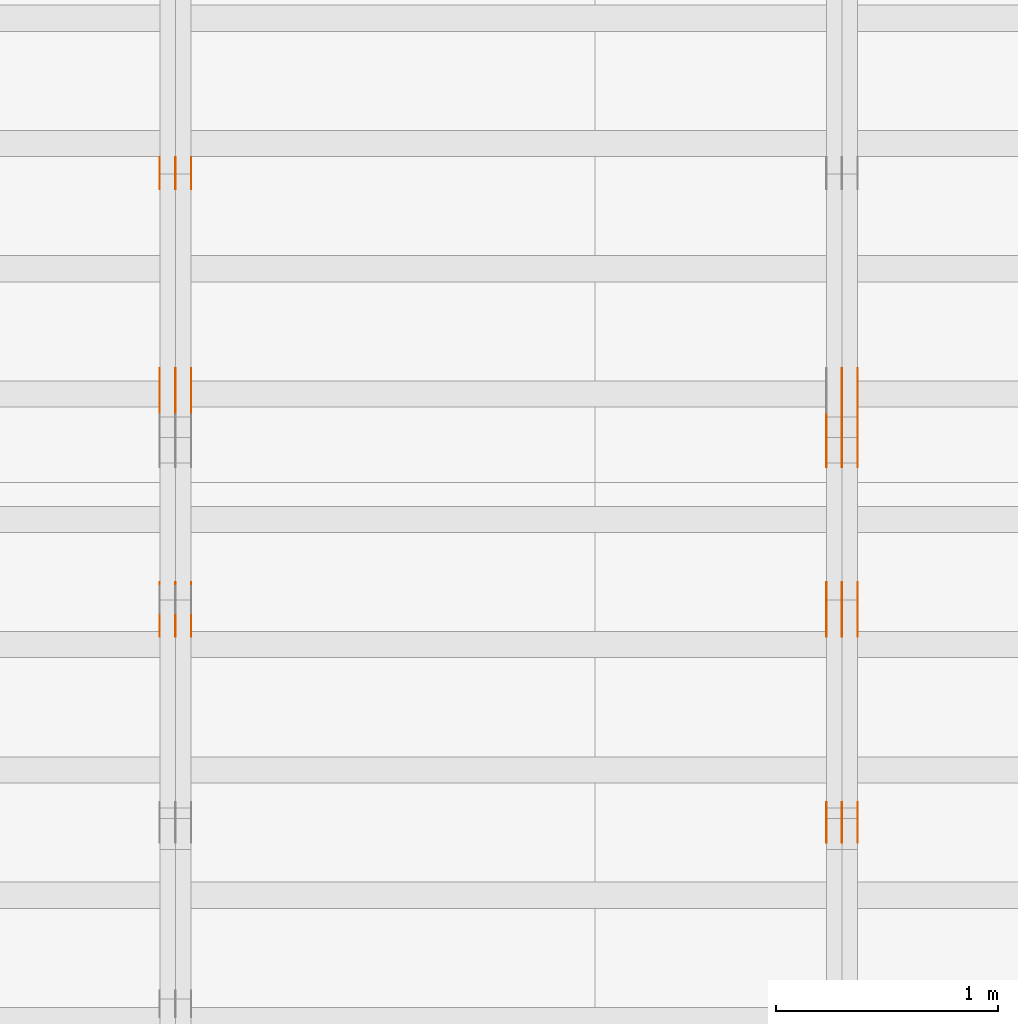
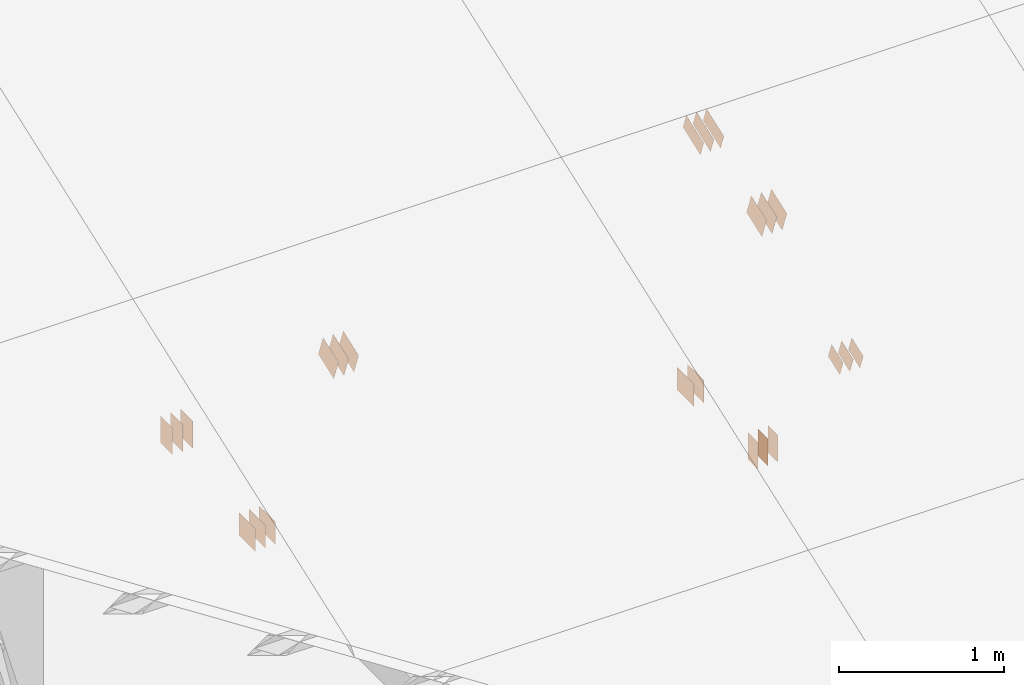
# One storey, part 71 of 189: 31 proxies.
"""IFC2X3 building model written with IfcOpenShell, lengths in millimetres."""

from ifc_helpers import new_model, entity, si_unit, converted_unit, derived_unit, direction, frame, frame_2d, origin, origin_2d_with_axis, place, context, subcontext, project, spatial, polyline, rectangle, outline, extrude, source, transform, mapped, material, type_object, type_shapes, element, save


model = new_model("IFC2X3")

# Units and contexts
model_context = context("Model", 3, precision=0.01, world=origin(), true_north=direction((6.12303176911189e-17, 1.0)))
body_context = subcontext(model_context, "Body", "Model", "MODEL_VIEW")
ifc_project = project(units=[si_unit("LENGTHUNIT", "METRE", prefix="MILLI"), si_unit("AREAUNIT", "SQUARE_METRE"), si_unit("VOLUMEUNIT", "CUBIC_METRE"), converted_unit("PLANEANGLEUNIT", "DEGREE", entity("IfcRatioMeasure", 0.0174532925199433), si_unit("PLANEANGLEUNIT", "RADIAN"), dimensions=[0, 0, 0, 0, 0, 0, 0]), si_unit("MASSUNIT", "GRAM", prefix="KILO"), derived_unit("MASSDENSITYUNIT", [(si_unit("MASSUNIT", "GRAM", prefix="KILO"), 1), (si_unit("LENGTHUNIT", "METRE"), -3)]), si_unit("TIMEUNIT", "SECOND"), si_unit("FREQUENCYUNIT", "HERTZ"), si_unit("THERMODYNAMICTEMPERATUREUNIT", "DEGREE_CELSIUS"), derived_unit("THERMALTRANSMITTANCEUNIT", [(si_unit("MASSUNIT", "GRAM", prefix="KILO"), 1), (si_unit("THERMODYNAMICTEMPERATUREUNIT", "KELVIN"), -1), (si_unit("TIMEUNIT", "SECOND"), -3)]), derived_unit("VOLUMETRICFLOWRATEUNIT", [(si_unit("LENGTHUNIT", "METRE"), 3), (si_unit("TIMEUNIT", "SECOND"), -1)]), si_unit("ELECTRICCURRENTUNIT", "AMPERE"), si_unit("ELECTRICVOLTAGEUNIT", "VOLT"), si_unit("POWERUNIT", "WATT"), si_unit("FORCEUNIT", "NEWTON"), si_unit("ILLUMINANCEUNIT", "LUX"), si_unit("LUMINOUSFLUXUNIT", "LUMEN"), si_unit("LUMINOUSINTENSITYUNIT", "CANDELA"), derived_unit("USERDEFINED", [(si_unit("MASSUNIT", "GRAM", prefix="KILO"), -1), (si_unit("LENGTHUNIT", "METRE"), -2), (si_unit("TIMEUNIT", "SECOND"), 3), (si_unit("LUMINOUSFLUXUNIT", "LUMEN"), 1)]), derived_unit("LINEARVELOCITYUNIT", [(si_unit("LENGTHUNIT", "METRE"), 1), (si_unit("TIMEUNIT", "SECOND"), -1)]), si_unit("PRESSUREUNIT", "PASCAL"), derived_unit("USERDEFINED", [(si_unit("LENGTHUNIT", "METRE"), -2), (si_unit("MASSUNIT", "GRAM", prefix="KILO"), 1), (si_unit("TIMEUNIT", "SECOND"), -2)])], contexts=[model_context])

# Site, building, storey
site_placement = place(None, origin())
site = spatial("IfcSite", under=ifc_project, at=site_placement, CompositionType="ELEMENT")
building_placement = place(site_placement, origin())
building = spatial("IfcBuilding", under=site, at=building_placement, CompositionType="ELEMENT")
storey_placement = place(building_placement, origin())
storey = spatial("IfcBuildingStorey", under=building, at=storey_placement, Name="Default", CompositionType="ELEMENT", Elevation=0.0)

# Proxies
ifc_material_1 = material(Name="IfcSurfaceStyle #47194")
building_element_proxy_type_1 = type_object("IfcBuildingElementProxyType", PredefinedType="NOTDEFINED", material=ifc_material_1)
shared_shape_1 = source(origin(), body_context, "Body", "SweptSolid", [
    extrude(rectangle(XDim=200.0, YDim=168.0, at=origin_2d_with_axis()), frame((100.0, 84.0, 0.0), z_axis=(0.0, 0.0, 1.0), x_axis=(-1.0, 0.0, 0.0)), (0.0, 0.0, 1.0), 1.3),
])
type_shapes(building_element_proxy_type_1, [shared_shape_1])
proxy_1_placement = place(building_placement, frame((6336.3, 5662.466796875, 206.5), z_axis=(-1.0, 0.0, 0.0), x_axis=(0.0, 1.0, 0.0)))
element("IfcBuildingElementProxy", 1, at=proxy_1_placement, inside=storey, type_object=building_element_proxy_type_1, material=ifc_material_1, context=body_context, shape_type="MappedRepresentation", body=[
    mapped(shared_shape_1, transform((0.0, 0.0, 0.0), scale=1.0)),
])
ifc_material_2 = material(Name="IfcSurfaceStyle #47137")
building_element_proxy_type_2 = type_object("IfcBuildingElementProxyType", PredefinedType="NOTDEFINED", material=ifc_material_2)
shared_shape_2 = source(origin(), body_context, "Body", "SweptSolid", [
    extrude(rectangle(XDim=200.0, YDim=168.0, at=origin_2d_with_axis()), frame((100.0, 84.0, 0.0), z_axis=(0.0, 0.0, 1.0), x_axis=(-1.0, 0.0, 0.0)), (0.0, 0.0, 1.0), 1.29999999999998),
])
type_shapes(building_element_proxy_type_2, [shared_shape_2])
proxy_2_placement = place(building_placement, frame((6265.0, 5662.466796875, 206.5), z_axis=(-1.0, 0.0, 0.0), x_axis=(0.0, 1.0, 0.0)))
element("IfcBuildingElementProxy", 2, at=proxy_2_placement, inside=storey, type_object=building_element_proxy_type_2, material=ifc_material_2, context=body_context, shape_type="MappedRepresentation", body=[
    mapped(shared_shape_2, transform((0.0, 0.0, 0.0), scale=1.0)),
])
ifc_material_3 = material(Name="IfcSurfaceStyle #47080")
building_element_proxy_type_3 = type_object("IfcBuildingElementProxyType", PredefinedType="NOTDEFINED", material=ifc_material_3)
shared_shape_3 = source(origin(), body_context, "Body", "SweptSolid", [
    extrude(rectangle(XDim=200.0, YDim=168.0, at=origin_2d_with_axis()), frame((100.0, 84.0, 0.0), z_axis=(0.0, 0.0, 1.0), x_axis=(-1.0, 0.0, 0.0)), (0.0, 0.0, 1.0), 1.29999999999998),
])
type_shapes(building_element_proxy_type_3, [shared_shape_3])
proxy_3_placement = place(building_placement, frame((6266.3, 5662.466796875, 206.5), z_axis=(-1.0, 0.0, 0.0), x_axis=(0.0, 1.0, 0.0)))
element("IfcBuildingElementProxy", 3, at=proxy_3_placement, inside=storey, type_object=building_element_proxy_type_3, material=ifc_material_3, context=body_context, shape_type="MappedRepresentation", body=[
    mapped(shared_shape_3, transform((0.0, 0.0, 0.0), scale=1.0)),
])
ifc_material_4 = material(Name="IfcSurfaceStyle #43546")
building_element_proxy_type_4 = type_object("IfcBuildingElementProxyType", PredefinedType="NOTDEFINED", material=ifc_material_4)
shared_shape_4 = source(origin(), body_context, "Body", "SweptSolid", [
    extrude(outline(polyline([(-112.500654374667, -59.9999021691247), (112.500117969231, -59.9999021691247), (112.500612624162, 59.9999021691247), (-112.500076218726, 59.9999021691247), (-112.500654374667, -59.9999021691247)])), frame((112.500612624162, 60.0003514046321, 0.0), z_axis=(0.0, 0.0, 1.0), x_axis=(-1.0, 0.0, 0.0)), (0.0, 0.0, 1.0), 1.3),
])
type_shapes(building_element_proxy_type_4, [shared_shape_4])
proxy_4_placement = place(building_placement, frame((6336.3, 5418.0703125, 2162.37353515625), z_axis=(-1.0, 0.0, 0.0), x_axis=(0.0, 0.939692620785908, 0.342020143325669)))
element("IfcBuildingElementProxy", 4, at=proxy_4_placement, inside=storey, type_object=building_element_proxy_type_4, material=ifc_material_4, context=body_context, shape_type="MappedRepresentation", body=[
    mapped(shared_shape_4, transform((0.0, 0.0, 0.0), scale=1.0)),
])
ifc_material_5 = material(Name="IfcSurfaceStyle #43489")
building_element_proxy_type_5 = type_object("IfcBuildingElementProxyType", PredefinedType="NOTDEFINED", material=ifc_material_5)
shared_shape_5 = source(origin(), body_context, "Body", "SweptSolid", [
    extrude(outline(polyline([(-112.500654374667, -59.9999021691247), (112.500117969231, -59.9999021691247), (112.500612624162, 59.9999021691247), (-112.500076218726, 59.9999021691247), (-112.500654374667, -59.9999021691247)])), frame((112.500612624162, 60.0003514046321, 0.0), z_axis=(0.0, 0.0, 1.0), x_axis=(-1.0, 0.0, 0.0)), (0.0, 0.0, 1.0), 1.29999999999998),
])
type_shapes(building_element_proxy_type_5, [shared_shape_5])
proxy_5_placement = place(building_placement, frame((6265.0, 5418.0703125, 2162.37353515625), z_axis=(-1.0, 0.0, 0.0), x_axis=(0.0, 0.939692620785908, 0.342020143325669)))
element("IfcBuildingElementProxy", 5, at=proxy_5_placement, inside=storey, type_object=building_element_proxy_type_5, material=ifc_material_5, context=body_context, shape_type="MappedRepresentation", body=[
    mapped(shared_shape_5, transform((0.0, 0.0, 0.0), scale=1.0)),
])
ifc_material_6 = material(Name="IfcSurfaceStyle #43432")
building_element_proxy_type_6 = type_object("IfcBuildingElementProxyType", PredefinedType="NOTDEFINED", material=ifc_material_6)
shared_shape_6 = source(origin(), body_context, "Body", "SweptSolid", [
    extrude(outline(polyline([(-112.500654374667, -59.9999021691247), (112.500117969231, -59.9999021691247), (112.500612624162, 59.9999021691247), (-112.500076218726, 59.9999021691247), (-112.500654374667, -59.9999021691247)])), frame((112.500612624162, 60.0003514046321, 0.0), z_axis=(0.0, 0.0, 1.0), x_axis=(-1.0, 0.0, 0.0)), (0.0, 0.0, 1.0), 1.29999999999998),
])
type_shapes(building_element_proxy_type_6, [shared_shape_6])
proxy_6_placement = place(building_placement, frame((6266.3, 5418.0703125, 2162.37353515625), z_axis=(-1.0, 0.0, 0.0), x_axis=(0.0, 0.939692620785908, 0.342020143325669)))
element("IfcBuildingElementProxy", 6, at=proxy_6_placement, inside=storey, type_object=building_element_proxy_type_6, material=ifc_material_6, context=body_context, shape_type="MappedRepresentation", body=[
    mapped(shared_shape_6, transform((0.0, 0.0, 0.0), scale=1.0)),
])
ifc_material_7 = material(Name="IfcSurfaceStyle #43375")
building_element_proxy_type_7 = type_object("IfcBuildingElementProxyType", PredefinedType="NOTDEFINED", material=ifc_material_7)
shared_shape_7 = source(origin(), body_context, "Body", "SweptSolid", [
    extrude(outline(polyline([(-112.500654374667, -59.9999021691247), (112.500117969231, -59.9999021691247), (112.500612624162, 59.9999021691247), (-112.500076218726, 59.9999021691247), (-112.500654374667, -59.9999021691247)])), frame((112.500612624162, 60.0003514046321, 0.0), z_axis=(0.0, 0.0, 1.0), x_axis=(-1.0, 0.0, 0.0)), (0.0, 0.0, 1.0), 1.29999999999999),
])
type_shapes(building_element_proxy_type_7, [shared_shape_7])
proxy_7_placement = place(building_placement, frame((6195.0, 5418.0703125, 2162.37353515625), z_axis=(-1.0, 0.0, 0.0), x_axis=(0.0, 0.939692620785908, 0.342020143325669)))
element("IfcBuildingElementProxy", 7, at=proxy_7_placement, inside=storey, type_object=building_element_proxy_type_7, material=ifc_material_7, context=body_context, shape_type="MappedRepresentation", body=[
    mapped(shared_shape_7, transform((0.0, 0.0, 0.0), scale=1.0)),
])
ifc_material_8 = material(Name="IfcSurfaceStyle #42862")
building_element_proxy_type_8 = type_object("IfcBuildingElementProxyType", PredefinedType="NOTDEFINED", material=ifc_material_8)
shared_shape_8 = source(origin(), body_context, "Body", "SweptSolid", [
    extrude(rectangle(XDim=200.0, YDim=120.0, at=origin_2d_with_axis()), frame((100.0, 60.0, 0.0), z_axis=(0.0, 0.0, 1.0), x_axis=(-1.0, 0.0, 0.0)), (0.0, 0.0, 1.0), 1.3),
])
type_shapes(building_element_proxy_type_8, [shared_shape_8])
proxy_8_placement = place(building_placement, frame((6336.3, 4760.65625, 145.0), z_axis=(-1.0, 0.0, 0.0), x_axis=(0.0, 0.0, 1.0)))
element("IfcBuildingElementProxy", 8, at=proxy_8_placement, inside=storey, type_object=building_element_proxy_type_8, material=ifc_material_8, context=body_context, shape_type="MappedRepresentation", body=[
    mapped(shared_shape_8, transform((0.0, 0.0, 0.0), scale=1.0)),
])
ifc_material_9 = material(Name="IfcSurfaceStyle #42805")
building_element_proxy_type_9 = type_object("IfcBuildingElementProxyType", PredefinedType="NOTDEFINED", material=ifc_material_9)
shared_shape_9 = source(origin(), body_context, "Body", "SweptSolid", [
    extrude(rectangle(XDim=200.0, YDim=120.0, at=origin_2d_with_axis()), frame((100.0, 60.0, 0.0), z_axis=(0.0, 0.0, 1.0), x_axis=(-1.0, 0.0, 0.0)), (0.0, 0.0, 1.0), 1.29999999999998),
])
type_shapes(building_element_proxy_type_9, [shared_shape_9])
proxy_9_placement = place(building_placement, frame((6265.0, 4760.65625, 145.0), z_axis=(-1.0, 0.0, 0.0), x_axis=(0.0, 0.0, 1.0)))
element("IfcBuildingElementProxy", 9, at=proxy_9_placement, inside=storey, type_object=building_element_proxy_type_9, material=ifc_material_9, context=body_context, shape_type="MappedRepresentation", body=[
    mapped(shared_shape_9, transform((0.0, 0.0, 0.0), scale=1.0)),
])
ifc_material_10 = material(Name="IfcSurfaceStyle #42748")
building_element_proxy_type_10 = type_object("IfcBuildingElementProxyType", PredefinedType="NOTDEFINED", material=ifc_material_10)
shared_shape_10 = source(origin(), body_context, "Body", "SweptSolid", [
    extrude(rectangle(XDim=200.0, YDim=120.0, at=origin_2d_with_axis()), frame((100.0, 60.0, 0.0), z_axis=(0.0, 0.0, 1.0), x_axis=(-1.0, 0.0, 0.0)), (0.0, 0.0, 1.0), 1.29999999999998),
])
type_shapes(building_element_proxy_type_10, [shared_shape_10])
proxy_10_placement = place(building_placement, frame((6266.3, 4760.65625, 145.0), z_axis=(-1.0, 0.0, 0.0), x_axis=(0.0, 0.0, 1.0)))
element("IfcBuildingElementProxy", 10, at=proxy_10_placement, inside=storey, type_object=building_element_proxy_type_10, material=ifc_material_10, context=body_context, shape_type="MappedRepresentation", body=[
    mapped(shared_shape_10, transform((0.0, 0.0, 0.0), scale=1.0)),
])
ifc_material_11 = material(Name="IfcSurfaceStyle #42691")
building_element_proxy_type_11 = type_object("IfcBuildingElementProxyType", PredefinedType="NOTDEFINED", material=ifc_material_11)
shared_shape_11 = source(origin(), body_context, "Body", "SweptSolid", [
    extrude(rectangle(XDim=200.0, YDim=120.0, at=origin_2d_with_axis()), frame((100.0, 60.0, 0.0), z_axis=(0.0, 0.0, 1.0), x_axis=(-1.0, 0.0, 0.0)), (0.0, 0.0, 1.0), 1.29999999999999),
])
type_shapes(building_element_proxy_type_11, [shared_shape_11])
proxy_11_placement = place(building_placement, frame((6195.0, 4760.65625, 145.0), z_axis=(-1.0, 0.0, 0.0), x_axis=(0.0, 0.0, 1.0)))
element("IfcBuildingElementProxy", 11, at=proxy_11_placement, inside=storey, type_object=building_element_proxy_type_11, material=ifc_material_11, context=body_context, shape_type="MappedRepresentation", body=[
    mapped(shared_shape_11, transform((0.0, 0.0, 0.0), scale=1.0)),
])
ifc_material_12 = material(Name="IfcSurfaceStyle #42634")
building_element_proxy_type_12 = type_object("IfcBuildingElementProxyType", PredefinedType="NOTDEFINED", material=ifc_material_12)
shared_shape_12 = source(origin(), body_context, "Body", "SweptSolid", [
    extrude(outline(polyline([(-74.9994515581384, -59.9999039432178), (74.9998536965286, -59.9999039432178), (75.0003483514593, 59.9999039432178), (-75.0007504898495, 59.9999039432178), (-74.9994515581384, -59.9999039432178)])), frame((75.0003483514593, 60.0003496305408, 0.0), z_axis=(0.0, 0.0, 1.0), x_axis=(-1.0, 0.0, 0.0)), (0.0, 0.0, 1.0), 1.3),
])
type_shapes(building_element_proxy_type_12, [shared_shape_12])
proxy_12_placement = place(building_placement, frame((6336.3, 3726.8984375, 1559.607421875), z_axis=(-1.0, 0.0, 0.0), x_axis=(0.0, 0.939692620785908, 0.342020143325669)))
element("IfcBuildingElementProxy", 12, at=proxy_12_placement, inside=storey, type_object=building_element_proxy_type_12, material=ifc_material_12, context=body_context, shape_type="MappedRepresentation", body=[
    mapped(shared_shape_12, transform((0.0, 0.0, 0.0), scale=1.0)),
])
ifc_material_13 = material(Name="IfcSurfaceStyle #42577")
building_element_proxy_type_13 = type_object("IfcBuildingElementProxyType", PredefinedType="NOTDEFINED", material=ifc_material_13)
shared_shape_13 = source(origin(), body_context, "Body", "SweptSolid", [
    extrude(outline(polyline([(-74.9994515581384, -59.9999039432178), (74.9998536965286, -59.9999039432178), (75.0003483514593, 59.9999039432178), (-75.0007504898495, 59.9999039432178), (-74.9994515581384, -59.9999039432178)])), frame((75.0003483514593, 60.0003496305408, 0.0), z_axis=(0.0, 0.0, 1.0), x_axis=(-1.0, 0.0, 0.0)), (0.0, 0.0, 1.0), 1.29999999999999),
])
type_shapes(building_element_proxy_type_13, [shared_shape_13])
proxy_13_placement = place(building_placement, frame((6265.0, 3726.8984375, 1559.607421875), z_axis=(-1.0, 0.0, 0.0), x_axis=(0.0, 0.939692620785908, 0.342020143325669)))
element("IfcBuildingElementProxy", 13, at=proxy_13_placement, inside=storey, type_object=building_element_proxy_type_13, material=ifc_material_13, context=body_context, shape_type="MappedRepresentation", body=[
    mapped(shared_shape_13, transform((0.0, 0.0, 0.0), scale=1.0)),
])
ifc_material_14 = material(Name="IfcSurfaceStyle #42520")
building_element_proxy_type_14 = type_object("IfcBuildingElementProxyType", PredefinedType="NOTDEFINED", material=ifc_material_14)
shared_shape_14 = source(origin(), body_context, "Body", "SweptSolid", [
    extrude(outline(polyline([(-74.9994515581384, -59.9999039432178), (74.9998536965286, -59.9999039432178), (75.0003483514593, 59.9999039432178), (-75.0007504898495, 59.9999039432178), (-74.9994515581384, -59.9999039432178)])), frame((75.0003483514593, 60.0003496305408, 0.0), z_axis=(0.0, 0.0, 1.0), x_axis=(-1.0, 0.0, 0.0)), (0.0, 0.0, 1.0), 1.29999999999999),
])
type_shapes(building_element_proxy_type_14, [shared_shape_14])
proxy_14_placement = place(building_placement, frame((6266.3, 3726.8984375, 1559.607421875), z_axis=(-1.0, 0.0, 0.0), x_axis=(0.0, 0.939692620785908, 0.342020143325669)))
element("IfcBuildingElementProxy", 14, at=proxy_14_placement, inside=storey, type_object=building_element_proxy_type_14, material=ifc_material_14, context=body_context, shape_type="MappedRepresentation", body=[
    mapped(shared_shape_14, transform((0.0, 0.0, 0.0), scale=1.0)),
])
ifc_material_15 = material(Name="IfcSurfaceStyle #42463")
building_element_proxy_type_15 = type_object("IfcBuildingElementProxyType", PredefinedType="NOTDEFINED", material=ifc_material_15)
shared_shape_15 = source(origin(), body_context, "Body", "SweptSolid", [
    extrude(outline(polyline([(-74.9994515581384, -59.9999039432178), (74.9998536965286, -59.9999039432178), (75.0003483514593, 59.9999039432178), (-75.0007504898495, 59.9999039432178), (-74.9994515581384, -59.9999039432178)])), frame((75.0003483514593, 60.0003496305408, 0.0), z_axis=(0.0, 0.0, 1.0), x_axis=(-1.0, 0.0, 0.0)), (0.0, 0.0, 1.0), 1.29999999999999),
])
type_shapes(building_element_proxy_type_15, [shared_shape_15])
proxy_15_placement = place(building_placement, frame((6195.0, 3726.8984375, 1559.607421875), z_axis=(-1.0, 0.0, 0.0), x_axis=(0.0, 0.939692620785908, 0.342020143325669)))
element("IfcBuildingElementProxy", 15, at=proxy_15_placement, inside=storey, type_object=building_element_proxy_type_15, material=ifc_material_15, context=body_context, shape_type="MappedRepresentation", body=[
    mapped(shared_shape_15, transform((0.0, 0.0, 0.0), scale=1.0)),
])
ifc_material_16 = material(Name="IfcSurfaceStyle #37966")
building_element_proxy_type_16 = type_object("IfcBuildingElementProxyType", PredefinedType="NOTDEFINED", material=ifc_material_16)
shared_shape_16 = source(origin(), body_context, "Body", "SweptSolid", [
    extrude(outline(polyline([(-99.9993269270171, -84.0000832532405), (99.9997189122032, -84.0000832532405), (99.9992851765118, 84.0000832532405), (-99.999677161698, 84.0000832532405), (-99.9993269270171, -84.0000832532405)])), frame((99.9999283659736, 84.0000832532405, 0.0), z_axis=(0.0, 0.0, 1.0), x_axis=(-1.0, 0.0, 0.0)), (0.0, 0.0, 1.0), 1.3),
])
type_shapes(building_element_proxy_type_16, [shared_shape_16])
proxy_16_placement = place(building_placement, frame((6336.3, 4654.06379965055, 2052.96988554922), z_axis=(-1.0, 0.0, 0.0), x_axis=(0.0, 0.939692620785908, 0.342020143325669)))
element("IfcBuildingElementProxy", 16, at=proxy_16_placement, inside=storey, type_object=building_element_proxy_type_16, material=ifc_material_16, context=body_context, shape_type="MappedRepresentation", body=[
    mapped(shared_shape_16, transform((0.0, 0.0, 0.0), scale=1.0)),
])
ifc_material_17 = material(Name="IfcSurfaceStyle #37909")
building_element_proxy_type_17 = type_object("IfcBuildingElementProxyType", PredefinedType="NOTDEFINED", material=ifc_material_17)
shared_shape_17 = source(origin(), body_context, "Body", "SweptSolid", [
    extrude(outline(polyline([(-99.9993269270171, -84.0000832532405), (99.9997189122032, -84.0000832532405), (99.9992851765118, 84.0000832532405), (-99.999677161698, 84.0000832532405), (-99.9993269270171, -84.0000832532405)])), frame((99.9999283659736, 84.0000832532405, 0.0), z_axis=(0.0, 0.0, 1.0), x_axis=(-1.0, 0.0, 0.0)), (0.0, 0.0, 1.0), 1.29999999999998),
])
type_shapes(building_element_proxy_type_17, [shared_shape_17])
proxy_17_placement = place(building_placement, frame((6265.0, 4654.06379965055, 2052.96988554922), z_axis=(-1.0, 0.0, 0.0), x_axis=(0.0, 0.939692620785908, 0.342020143325669)))
element("IfcBuildingElementProxy", 17, at=proxy_17_placement, inside=storey, type_object=building_element_proxy_type_17, material=ifc_material_17, context=body_context, shape_type="MappedRepresentation", body=[
    mapped(shared_shape_17, transform((0.0, 0.0, 0.0), scale=1.0)),
])
ifc_material_18 = material(Name="IfcSurfaceStyle #37852")
building_element_proxy_type_18 = type_object("IfcBuildingElementProxyType", PredefinedType="NOTDEFINED", material=ifc_material_18)
shared_shape_18 = source(origin(), body_context, "Body", "SweptSolid", [
    extrude(outline(polyline([(-99.9993269270171, -84.0000832532405), (99.9997189122032, -84.0000832532405), (99.9992851765118, 84.0000832532405), (-99.999677161698, 84.0000832532405), (-99.9993269270171, -84.0000832532405)])), frame((99.9999283659736, 84.0000832532405, 0.0), z_axis=(0.0, 0.0, 1.0), x_axis=(-1.0, 0.0, 0.0)), (0.0, 0.0, 1.0), 1.29999999999998),
])
type_shapes(building_element_proxy_type_18, [shared_shape_18])
proxy_18_placement = place(building_placement, frame((6266.3, 4654.06379965055, 2052.96988554922), z_axis=(-1.0, 0.0, 0.0), x_axis=(0.0, 0.939692620785908, 0.342020143325669)))
element("IfcBuildingElementProxy", 18, at=proxy_18_placement, inside=storey, type_object=building_element_proxy_type_18, material=ifc_material_18, context=body_context, shape_type="MappedRepresentation", body=[
    mapped(shared_shape_18, transform((0.0, 0.0, 0.0), scale=1.0)),
])
ifc_material_19 = material(Name="IfcSurfaceStyle #37795")
building_element_proxy_type_19 = type_object("IfcBuildingElementProxyType", PredefinedType="NOTDEFINED", material=ifc_material_19)
shared_shape_19 = source(origin(), body_context, "Body", "SweptSolid", [
    extrude(outline(polyline([(-99.9993269270171, -84.0000832532405), (99.9997189122032, -84.0000832532405), (99.9992851765118, 84.0000832532405), (-99.999677161698, 84.0000832532405), (-99.9993269270171, -84.0000832532405)])), frame((99.9999283659736, 84.0000832532405, 0.0), z_axis=(0.0, 0.0, 1.0), x_axis=(-1.0, 0.0, 0.0)), (0.0, 0.0, 1.0), 1.29999999999999),
])
type_shapes(building_element_proxy_type_19, [shared_shape_19])
proxy_19_placement = place(building_placement, frame((6195.0, 4654.06379965055, 2052.96988554922), z_axis=(-1.0, 0.0, 0.0), x_axis=(0.0, 0.939692620785908, 0.342020143325669)))
element("IfcBuildingElementProxy", 19, at=proxy_19_placement, inside=storey, type_object=building_element_proxy_type_19, material=ifc_material_19, context=body_context, shape_type="MappedRepresentation", body=[
    mapped(shared_shape_19, transform((0.0, 0.0, 0.0), scale=1.0)),
])
ifc_material_20 = material(Name="IfcSurfaceStyle #31632")
building_element_proxy_type_20 = type_object("IfcBuildingElementProxyType", PredefinedType="NOTDEFINED", material=ifc_material_20)
shared_shape_20 = source(origin(), body_context, "Body", "SweptSolid", [
    extrude(rectangle(XDim=200.0, YDim=144.0, at=frame_2d((1.4210854715202e-14, 0.0), x_axis=(1.0, 0.0))), frame((100.0, 72.0, 0.0), z_axis=(0.0, 0.0, 1.0), x_axis=(-1.0, 0.0, 0.0)), (0.0, 0.0, 1.0), 1.3),
])
type_shapes(building_element_proxy_type_20, [shared_shape_20])
proxy_20_placement = place(building_placement, frame((3336.3, 6668.833984375, 145.0), z_axis=(-1.0, 0.0, 0.0), x_axis=(0.0, 0.0, 1.0)))
element("IfcBuildingElementProxy", 20, at=proxy_20_placement, inside=storey, type_object=building_element_proxy_type_20, material=ifc_material_20, context=body_context, shape_type="MappedRepresentation", body=[
    mapped(shared_shape_20, transform((0.0, 0.0, 0.0), scale=1.0)),
])
ifc_material_21 = material(Name="IfcSurfaceStyle #31575")
building_element_proxy_type_21 = type_object("IfcBuildingElementProxyType", PredefinedType="NOTDEFINED", material=ifc_material_21)
shared_shape_21 = source(origin(), body_context, "Body", "SweptSolid", [
    extrude(rectangle(XDim=200.0, YDim=144.0, at=frame_2d((1.4210854715202e-14, 0.0), x_axis=(1.0, 0.0))), frame((100.0, 72.0, 0.0), z_axis=(0.0, 0.0, 1.0), x_axis=(-1.0, 0.0, 0.0)), (0.0, 0.0, 1.0), 1.29999999999998),
])
type_shapes(building_element_proxy_type_21, [shared_shape_21])
proxy_21_placement = place(building_placement, frame((3265.0, 6668.833984375, 145.0), z_axis=(-1.0, 0.0, 0.0), x_axis=(0.0, 0.0, 1.0)))
element("IfcBuildingElementProxy", 21, at=proxy_21_placement, inside=storey, type_object=building_element_proxy_type_21, material=ifc_material_21, context=body_context, shape_type="MappedRepresentation", body=[
    mapped(shared_shape_21, transform((0.0, 0.0, 0.0), scale=1.0)),
])
ifc_material_22 = material(Name="IfcSurfaceStyle #31518")
building_element_proxy_type_22 = type_object("IfcBuildingElementProxyType", PredefinedType="NOTDEFINED", material=ifc_material_22)
shared_shape_22 = source(origin(), body_context, "Body", "SweptSolid", [
    extrude(rectangle(XDim=200.0, YDim=144.0, at=frame_2d((1.4210854715202e-14, 0.0), x_axis=(1.0, 0.0))), frame((100.0, 72.0, 0.0), z_axis=(0.0, 0.0, 1.0), x_axis=(-1.0, 0.0, 0.0)), (0.0, 0.0, 1.0), 1.29999999999998),
])
type_shapes(building_element_proxy_type_22, [shared_shape_22])
proxy_22_placement = place(building_placement, frame((3266.3, 6668.833984375, 145.0), z_axis=(-1.0, 0.0, 0.0), x_axis=(0.0, 0.0, 1.0)))
element("IfcBuildingElementProxy", 22, at=proxy_22_placement, inside=storey, type_object=building_element_proxy_type_22, material=ifc_material_22, context=body_context, shape_type="MappedRepresentation", body=[
    mapped(shared_shape_22, transform((0.0, 0.0, 0.0), scale=1.0)),
])
ifc_material_23 = material(Name="IfcSurfaceStyle #31461")
building_element_proxy_type_23 = type_object("IfcBuildingElementProxyType", PredefinedType="NOTDEFINED", material=ifc_material_23)
shared_shape_23 = source(origin(), body_context, "Body", "SweptSolid", [
    extrude(rectangle(XDim=200.0, YDim=144.0, at=frame_2d((1.4210854715202e-14, 0.0), x_axis=(1.0, 0.0))), frame((100.0, 72.0, 0.0), z_axis=(0.0, 0.0, 1.0), x_axis=(-1.0, 0.0, 0.0)), (0.0, 0.0, 1.0), 1.29999999999999),
])
type_shapes(building_element_proxy_type_23, [shared_shape_23])
proxy_23_placement = place(building_placement, frame((3195.0, 6668.833984375, 145.0), z_axis=(-1.0, 0.0, 0.0), x_axis=(0.0, 0.0, 1.0)))
element("IfcBuildingElementProxy", 23, at=proxy_23_placement, inside=storey, type_object=building_element_proxy_type_23, material=ifc_material_23, context=body_context, shape_type="MappedRepresentation", body=[
    mapped(shared_shape_23, transform((0.0, 0.0, 0.0), scale=1.0)),
])
ifc_material_24 = material(Name="IfcSurfaceStyle #31404")
building_element_proxy_type_24 = type_object("IfcBuildingElementProxyType", PredefinedType="NOTDEFINED", material=ifc_material_24)
shared_shape_24 = source(origin(), body_context, "Body", "SweptSolid", [
    extrude(rectangle(XDim=200.0, YDim=168.0, at=origin_2d_with_axis()), frame((100.0, 84.0, 0.0), z_axis=(0.0, 0.0, 1.0), x_axis=(-1.0, 0.0, 0.0)), (0.0, 0.0, 1.0), 1.3),
])
type_shapes(building_element_proxy_type_24, [shared_shape_24])
proxy_24_placement = place(building_placement, frame((3336.3, 5662.466796875, 206.5), z_axis=(-1.0, 0.0, 0.0), x_axis=(0.0, 1.0, 0.0)))
element("IfcBuildingElementProxy", 24, at=proxy_24_placement, inside=storey, type_object=building_element_proxy_type_24, material=ifc_material_24, context=body_context, shape_type="MappedRepresentation", body=[
    mapped(shared_shape_24, transform((0.0, 0.0, 0.0), scale=1.0)),
])
ifc_material_25 = material(Name="IfcSurfaceStyle #31347")
building_element_proxy_type_25 = type_object("IfcBuildingElementProxyType", PredefinedType="NOTDEFINED", material=ifc_material_25)
shared_shape_25 = source(origin(), body_context, "Body", "SweptSolid", [
    extrude(rectangle(XDim=200.0, YDim=168.0, at=origin_2d_with_axis()), frame((100.0, 84.0, 0.0), z_axis=(0.0, 0.0, 1.0), x_axis=(-1.0, 0.0, 0.0)), (0.0, 0.0, 1.0), 1.29999999999998),
])
type_shapes(building_element_proxy_type_25, [shared_shape_25])
proxy_25_placement = place(building_placement, frame((3265.0, 5662.466796875, 206.5), z_axis=(-1.0, 0.0, 0.0), x_axis=(0.0, 1.0, 0.0)))
element("IfcBuildingElementProxy", 25, at=proxy_25_placement, inside=storey, type_object=building_element_proxy_type_25, material=ifc_material_25, context=body_context, shape_type="MappedRepresentation", body=[
    mapped(shared_shape_25, transform((0.0, 0.0, 0.0), scale=1.0)),
])
ifc_material_26 = material(Name="IfcSurfaceStyle #31290")
building_element_proxy_type_26 = type_object("IfcBuildingElementProxyType", PredefinedType="NOTDEFINED", material=ifc_material_26)
shared_shape_26 = source(origin(), body_context, "Body", "SweptSolid", [
    extrude(rectangle(XDim=200.0, YDim=168.0, at=origin_2d_with_axis()), frame((100.0, 84.0, 0.0), z_axis=(0.0, 0.0, 1.0), x_axis=(-1.0, 0.0, 0.0)), (0.0, 0.0, 1.0), 1.29999999999998),
])
type_shapes(building_element_proxy_type_26, [shared_shape_26])
proxy_26_placement = place(building_placement, frame((3266.3, 5662.466796875, 206.5), z_axis=(-1.0, 0.0, 0.0), x_axis=(0.0, 1.0, 0.0)))
element("IfcBuildingElementProxy", 26, at=proxy_26_placement, inside=storey, type_object=building_element_proxy_type_26, material=ifc_material_26, context=body_context, shape_type="MappedRepresentation", body=[
    mapped(shared_shape_26, transform((0.0, 0.0, 0.0), scale=1.0)),
])
ifc_material_27 = material(Name="IfcSurfaceStyle #31233")
building_element_proxy_type_27 = type_object("IfcBuildingElementProxyType", PredefinedType="NOTDEFINED", material=ifc_material_27)
shared_shape_27 = source(origin(), body_context, "Body", "SweptSolid", [
    extrude(rectangle(XDim=200.0, YDim=168.0, at=origin_2d_with_axis()), frame((100.0, 84.0, 0.0), z_axis=(0.0, 0.0, 1.0), x_axis=(-1.0, 0.0, 0.0)), (0.0, 0.0, 1.0), 1.29999999999999),
])
type_shapes(building_element_proxy_type_27, [shared_shape_27])
proxy_27_placement = place(building_placement, frame((3195.0, 5662.466796875, 206.5), z_axis=(-1.0, 0.0, 0.0), x_axis=(0.0, 1.0, 0.0)))
element("IfcBuildingElementProxy", 27, at=proxy_27_placement, inside=storey, type_object=building_element_proxy_type_27, material=ifc_material_27, context=body_context, shape_type="MappedRepresentation", body=[
    mapped(shared_shape_27, transform((0.0, 0.0, 0.0), scale=1.0)),
])
ifc_material_28 = material(Name="IfcSurfaceStyle #22176")
building_element_proxy_type_28 = type_object("IfcBuildingElementProxyType", PredefinedType="NOTDEFINED", material=ifc_material_28)
shared_shape_28 = source(origin(), body_context, "Body", "SweptSolid", [
    extrude(outline(polyline([(-99.9993269270171, -84.0000832532405), (99.9997189122032, -84.0000832532405), (99.9992851765118, 84.0000832532405), (-99.999677161698, 84.0000832532405), (-99.9993269270171, -84.0000832532405)])), frame((99.9999283659736, 84.0000832532405, 0.0), z_axis=(0.0, 0.0, 1.0), x_axis=(-1.0, 0.0, 0.0)), (0.0, 0.0, 1.0), 1.3),
])
type_shapes(building_element_proxy_type_28, [shared_shape_28])
proxy_28_placement = place(building_placement, frame((3336.3, 4654.06379965055, 2052.96988554922), z_axis=(-1.0, 0.0, 0.0), x_axis=(0.0, 0.939692620785908, 0.342020143325669)))
element("IfcBuildingElementProxy", 28, at=proxy_28_placement, inside=storey, type_object=building_element_proxy_type_28, material=ifc_material_28, context=body_context, shape_type="MappedRepresentation", body=[
    mapped(shared_shape_28, transform((0.0, 0.0, 0.0), scale=1.0)),
])
ifc_material_29 = material(Name="IfcSurfaceStyle #22119")
building_element_proxy_type_29 = type_object("IfcBuildingElementProxyType", PredefinedType="NOTDEFINED", material=ifc_material_29)
shared_shape_29 = source(origin(), body_context, "Body", "SweptSolid", [
    extrude(outline(polyline([(-99.9993269270171, -84.0000832532405), (99.9997189122032, -84.0000832532405), (99.9992851765118, 84.0000832532405), (-99.999677161698, 84.0000832532405), (-99.9993269270171, -84.0000832532405)])), frame((99.9999283659736, 84.0000832532405, 0.0), z_axis=(0.0, 0.0, 1.0), x_axis=(-1.0, 0.0, 0.0)), (0.0, 0.0, 1.0), 1.29999999999998),
])
type_shapes(building_element_proxy_type_29, [shared_shape_29])
proxy_29_placement = place(building_placement, frame((3265.0, 4654.06379965055, 2052.96988554922), z_axis=(-1.0, 0.0, 0.0), x_axis=(0.0, 0.939692620785908, 0.342020143325669)))
element("IfcBuildingElementProxy", 29, at=proxy_29_placement, inside=storey, type_object=building_element_proxy_type_29, material=ifc_material_29, context=body_context, shape_type="MappedRepresentation", body=[
    mapped(shared_shape_29, transform((0.0, 0.0, 0.0), scale=1.0)),
])
ifc_material_30 = material(Name="IfcSurfaceStyle #22062")
building_element_proxy_type_30 = type_object("IfcBuildingElementProxyType", PredefinedType="NOTDEFINED", material=ifc_material_30)
shared_shape_30 = source(origin(), body_context, "Body", "SweptSolid", [
    extrude(outline(polyline([(-99.9993269270171, -84.0000832532405), (99.9997189122032, -84.0000832532405), (99.9992851765118, 84.0000832532405), (-99.999677161698, 84.0000832532405), (-99.9993269270171, -84.0000832532405)])), frame((99.9999283659736, 84.0000832532405, 0.0), z_axis=(0.0, 0.0, 1.0), x_axis=(-1.0, 0.0, 0.0)), (0.0, 0.0, 1.0), 1.29999999999998),
])
type_shapes(building_element_proxy_type_30, [shared_shape_30])
proxy_30_placement = place(building_placement, frame((3266.3, 4654.06379965055, 2052.96988554922), z_axis=(-1.0, 0.0, 0.0), x_axis=(0.0, 0.939692620785908, 0.342020143325669)))
element("IfcBuildingElementProxy", 30, at=proxy_30_placement, inside=storey, type_object=building_element_proxy_type_30, material=ifc_material_30, context=body_context, shape_type="MappedRepresentation", body=[
    mapped(shared_shape_30, transform((0.0, 0.0, 0.0), scale=1.0)),
])
ifc_material_31 = material(Name="IfcSurfaceStyle #22005")
building_element_proxy_type_31 = type_object("IfcBuildingElementProxyType", PredefinedType="NOTDEFINED", material=ifc_material_31)
shared_shape_31 = source(origin(), body_context, "Body", "SweptSolid", [
    extrude(outline(polyline([(-99.9993269270171, -84.0000832532405), (99.9997189122032, -84.0000832532405), (99.9992851765118, 84.0000832532405), (-99.999677161698, 84.0000832532405), (-99.9993269270171, -84.0000832532405)])), frame((99.9999283659736, 84.0000832532405, 0.0), z_axis=(0.0, 0.0, 1.0), x_axis=(-1.0, 0.0, 0.0)), (0.0, 0.0, 1.0), 1.29999999999999),
])
type_shapes(building_element_proxy_type_31, [shared_shape_31])
proxy_31_placement = place(building_placement, frame((3195.0, 4654.06379965055, 2052.96988554922), z_axis=(-1.0, 0.0, 0.0), x_axis=(0.0, 0.939692620785908, 0.342020143325669)))
element("IfcBuildingElementProxy", 31, at=proxy_31_placement, inside=storey, type_object=building_element_proxy_type_31, material=ifc_material_31, context=body_context, shape_type="MappedRepresentation", body=[
    mapped(shared_shape_31, transform((0.0, 0.0, 0.0), scale=1.0)),
])

save(model, "model.ifc")
